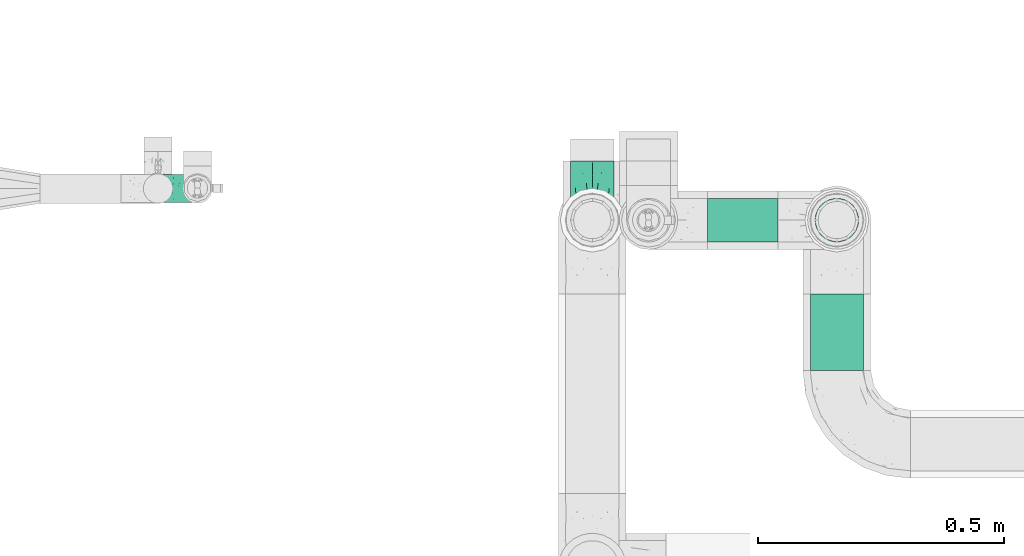
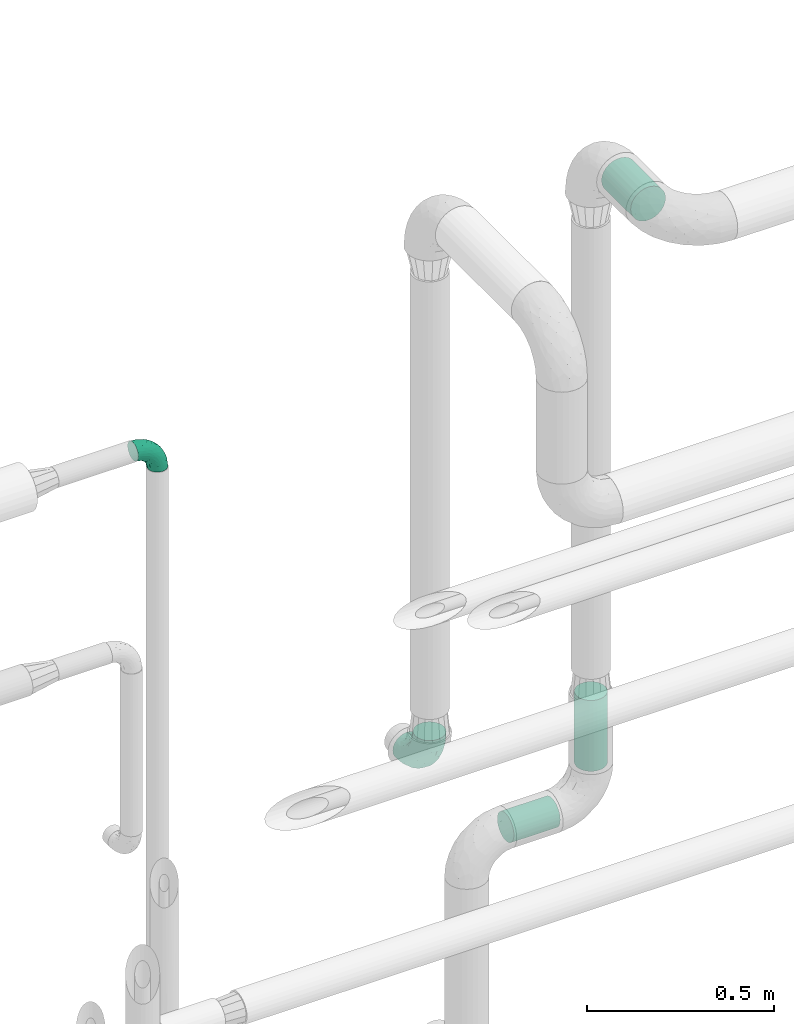
# One storey, part 720 of 827: 3 flow segments, 2 flow fittings.
"""IFC2X3 building model written with IfcOpenShell, lengths in millimetres."""

from ifc_helpers import new_model, entity, si_unit, converted_unit, derived_unit, direction, frame, origin, origin_2d_with_axis, place, context, subcontext, project, spatial, circle, extrude, faceted_brep, source, transform, mapped, material, type_object, type_shapes, element, save


model = new_model("IFC2X3")

# Units and contexts
model_context = context("Model", 3, precision=0.01, world=origin(), true_north=direction((6.12303176911189e-17, 1.0)))
body_context = subcontext(model_context, "Body", "Model", "MODEL_VIEW")
ifc_project = project(units=[si_unit("LENGTHUNIT", "METRE", prefix="MILLI"), si_unit("AREAUNIT", "SQUARE_METRE"), si_unit("VOLUMEUNIT", "CUBIC_METRE"), converted_unit("PLANEANGLEUNIT", "DEGREE", entity("IfcRatioMeasure", 0.0174532925199433), si_unit("PLANEANGLEUNIT", "RADIAN"), dimensions=[0, 0, 0, 0, 0, 0, 0]), si_unit("MASSUNIT", "GRAM", prefix="KILO"), derived_unit("MASSDENSITYUNIT", [(si_unit("MASSUNIT", "GRAM", prefix="KILO"), 1), (si_unit("LENGTHUNIT", "METRE"), -3)]), derived_unit("MOMENTOFINERTIAUNIT", [(si_unit("LENGTHUNIT", "METRE"), 4)]), si_unit("TIMEUNIT", "SECOND"), si_unit("FREQUENCYUNIT", "HERTZ"), si_unit("THERMODYNAMICTEMPERATUREUNIT", "DEGREE_CELSIUS"), derived_unit("THERMALTRANSMITTANCEUNIT", [(si_unit("MASSUNIT", "GRAM", prefix="KILO"), 1), (si_unit("THERMODYNAMICTEMPERATUREUNIT", "KELVIN"), -1), (si_unit("TIMEUNIT", "SECOND"), -3)]), derived_unit("VOLUMETRICFLOWRATEUNIT", [(si_unit("LENGTHUNIT", "METRE"), 3), (si_unit("TIMEUNIT", "SECOND"), -1)]), derived_unit("MASSFLOWRATEUNIT", [(si_unit("MASSUNIT", "GRAM", prefix="KILO"), 1), (si_unit("TIMEUNIT", "SECOND"), -1)]), derived_unit("ROTATIONALFREQUENCYUNIT", [(si_unit("TIMEUNIT", "SECOND"), -1)]), si_unit("ELECTRICCURRENTUNIT", "AMPERE"), si_unit("ELECTRICVOLTAGEUNIT", "VOLT"), si_unit("POWERUNIT", "WATT"), si_unit("FORCEUNIT", "NEWTON", prefix="KILO"), si_unit("ILLUMINANCEUNIT", "LUX"), si_unit("LUMINOUSFLUXUNIT", "LUMEN"), si_unit("LUMINOUSINTENSITYUNIT", "CANDELA"), derived_unit("USERDEFINED", [(si_unit("MASSUNIT", "GRAM", prefix="KILO"), -1), (si_unit("LENGTHUNIT", "METRE"), -2), (si_unit("TIMEUNIT", "SECOND"), 3), (si_unit("LUMINOUSFLUXUNIT", "LUMEN"), 1)]), derived_unit("LINEARVELOCITYUNIT", [(si_unit("LENGTHUNIT", "METRE"), 1), (si_unit("TIMEUNIT", "SECOND"), -1)]), si_unit("PRESSUREUNIT", "PASCAL"), derived_unit("USERDEFINED", [(si_unit("LENGTHUNIT", "METRE"), -2), (si_unit("MASSUNIT", "GRAM", prefix="KILO"), 1), (si_unit("TIMEUNIT", "SECOND"), -2)]), derived_unit("LINEARFORCEUNIT", [(si_unit("MASSUNIT", "GRAM", prefix="KILO"), 1), (si_unit("LENGTHUNIT", "METRE"), 1), (si_unit("TIMEUNIT", "SECOND"), -2), (si_unit("LENGTHUNIT", "METRE"), -1)]), derived_unit("PLANARFORCEUNIT", [(si_unit("MASSUNIT", "GRAM", prefix="KILO"), 1), (si_unit("LENGTHUNIT", "METRE"), 1), (si_unit("TIMEUNIT", "SECOND"), -2), (si_unit("LENGTHUNIT", "METRE"), -2)])], contexts=[model_context])

# Site, building, storey
site_placement = place(None, origin())
site = spatial("IfcSite", under=ifc_project, at=site_placement, CompositionType="ELEMENT")
building_placement = place(site_placement, origin())
building = spatial("IfcBuilding", under=site, at=building_placement, CompositionType="ELEMENT")
storey_placement = place(building_placement, frame((0.0, 0.0, 28200.0)))
storey = spatial("IfcBuildingStorey", under=building, at=storey_placement, Name="08", CompositionType="ELEMENT", Elevation=28200.0)

# Flow segments
pipe_segment_type = type_object("IfcPipeSegmentType", PredefinedType="NOTDEFINED")
flow_segment_1_placement = place(storey_placement, frame((56052.95, 18330.1, 3444.15)))
element("IfcFlowSegment", 1, at=flow_segment_1_placement, inside=storey, type_object=pipe_segment_type, context=body_context, shape_type="SweptSolid", body=[
    extrude(circle(Radius=54.0, at=origin_2d_with_axis()), frame((55.6, 0.0, 55.6), z_axis=(0.0, 1.0, 0.0), x_axis=(1.0, 0.0, 0.0)), (0.0, 0.0, 1.0), 155.890486759072),
])
flow_segment_2_placement = place(storey_placement, frame((55845.5, 18589.89, 1327.79)))
element("IfcFlowSegment", 2, at=flow_segment_2_placement, inside=storey, type_object=pipe_segment_type, context=body_context, shape_type="SweptSolid", body=[
    extrude(circle(Radius=44.5, at=origin_2d_with_axis()), frame((0.0, 46.1, 46.1), z_axis=(1.0, 0.0, 0.0), x_axis=(0.0, 1.0, 0.0)), (0.0, 0.0, 1.0), 143.048447506268),
])
flow_segment_3_placement = place(storey_placement, frame((56062.45, 18589.89, 1493.89)))
element("IfcFlowSegment", 3, at=flow_segment_3_placement, inside=storey, type_object=pipe_segment_type, context=body_context, shape_type="SweptSolid", body=[
    extrude(circle(Radius=44.5, at=origin_2d_with_axis()), frame((46.1, 46.1, 0.0)), (0.0, 0.0, 1.0), 231.111239088707),
])

# Flow fittings
ifc_material = material()
pipe_fitting_type_1 = type_object("IfcPipeFittingType", Name="ADSK_2", PredefinedType="NOTDEFINED", material=ifc_material)
shared_shape_1 = source(origin(), body_context, "Body", "Brep", [
    faceted_brep([(-120.0, 22.25, -38.54), (-120.0, 11.52, -42.98), (-120.0, 0.0, -44.5), (-120.0, -11.52, -42.98), (-120.0, -22.25, -38.54), (-120.0, -31.47, -31.47), (-120.0, -38.54, -22.25), (-120.0, -42.98, -11.52), (-120.0, -44.5, 0.0), (-120.0, -42.98, 11.52), (-120.0, -38.54, 22.25), (-120.0, -31.47, 31.47), (-120.0, -22.25, 38.54), (-120.0, -11.52, 42.98), (-120.0, 0.0, 44.5), (-120.0, 11.52, 42.98), (-120.0, 22.25, 38.54), (-120.0, 31.47, 31.47), (-120.0, 38.54, 22.25), (-120.0, 42.98, 11.52), (-120.0, 44.5, 0.0), (-120.0, 42.98, -11.52), (-120.0, 38.54, -22.25), (-120.0, 31.47, -31.47), (0.0, 120.0, -44.5), (-11.52, 120.0, -42.98), (-22.25, 120.0, -38.54), (-31.47, 120.0, -31.47), (-38.54, 120.0, -22.25), (-42.98, 120.0, -11.52), (-44.5, 120.0, 0.0), (-42.98, 120.0, 11.52), (-38.54, 120.0, 22.25), (-31.47, 120.0, 31.47), (-22.25, 120.0, 38.54), (-11.52, 120.0, 42.98), (0.0, 120.0, 44.5), (11.52, 120.0, 42.98), (22.25, 120.0, 38.54), (31.47, 120.0, 31.47), (38.54, 120.0, 22.25), (42.98, 120.0, 11.52), (44.5, 120.0, 0.0), (42.98, 120.0, -11.52), (38.54, 120.0, -22.25), (31.47, 120.0, -31.47), (22.25, 120.0, -38.54), (11.52, 120.0, -42.98), (-20.51, 85.66, 41.98), (-29.31, 93.55, 36.45), (-98.0, -41.6, 0.0), (-80.92, -37.22, 14.68), (-66.68, -9.63, 39.67), (-84.59, -24.55, 33.9), (-50.35, -12.87, 32.85), (-77.42, -38.89, 0.0), (-22.01, -9.62, 13.21), (-37.75, -22.46, 0.0), (-20.72, -9.39, 0.0), (-89.18, -33.47, 25.4), (12.87, 50.35, 32.85), (24.55, 84.59, 33.9), (9.63, 66.68, 39.67), (-49.55, -27.06, 11.21), (-28.67, -9.99, 21.67), (-52.01, -22.41, 23.47), (-95.53, -16.28, 40.49), (-86.01, -3.42, 43.77), (22.41, 52.01, 23.47), (9.05, 21.37, 13.44), (26.5, 49.37, 12.73), (33.47, 89.18, 25.4), (37.22, 80.92, 14.68), (16.28, 95.53, 40.49), (3.42, 86.01, 43.77), (-7.84, 52.6, 43.16), (-84.39, 31.88, 36.84), (-30.52, 34.28, 44.33), (-21.99, 28.55, 42.22), (-93.56, 38.23, 28.63), (-65.04, 31.74, 41.51), (-91.98, 19.0, 41.83), (-34.03, 70.24, 39.41), (-96.36, 44.0, 18.64), (-98.49, 46.74, 8.65), (-76.5, 56.97, 9.76), (-4.96, 4.47, 11.32), (-7.16, 6.18, 18.93), (-56.62, 75.93, 12.18), (-66.61, 66.61, 0.0), (-92.12, 7.25, 44.33), (-7.23, 92.66, 44.32), (30.68, 57.59, 0.0), (-44.45, 94.8, 18.75), (-36.39, 101.98, 28.14), (-46.83, 97.45, 9.69), (-38.03, 47.61, 43.21), (-24.7, 65.7, 43.29), (41.6, 98.0, 0.0), (-54.11, 72.8, 21.53), (-47.95, 9.75, 42.93), (-18.65, 18.65, 37.89), (-91.11, 50.25, 0.0), (-50.25, 91.11, 0.0), (-57.59, -30.68, 0.0), (-44.16, 67.2, 34.92), (-55.15, 62.16, 29.74), (-68.1, 47.21, 32.31), (-51.09, 51.09, 38.36), (-16.69, 62.62, 44.46), (-58.26, 18.84, 44.48), (-71.55, 55.71, 20.49), (-43.13, 80.04, 29.45), (-37.23, 0.88, 36.78), (-18.15, 10.22, 33.09), (5.51, 28.08, 26.74), (-3.68, 3.68, 0.0), (9.39, 20.72, 0.0), (-2.58, 27.98, 33.59), (-2.38, 41.22, 38.93), (-16.09, 4.55, 27.06), (38.89, 77.42, 0.0), (22.46, 37.75, 0.0), (-92.66, 7.23, -44.32), (-22.01, -9.62, -13.21), (-49.81, -26.66, -12.91), (-28.67, -9.99, -21.67), (-62.62, 16.69, -44.46), (-65.04, 31.74, -41.51), (-38.89, 47.26, -43.11), (-56.62, 75.93, -12.18), (-93.56, 38.23, -28.63), (-84.39, 31.88, -36.84), (16.28, 95.53, -40.49), (3.42, 86.01, -43.77), (-98.49, 46.74, -8.65), (-44.45, 94.8, -18.75), (-54.11, 72.8, -21.53), (-76.5, 56.97, -9.76), (24.55, 84.59, -33.9), (9.63, 66.68, -39.67), (-96.36, 44.0, -18.64), (-29.4, 93.16, -36.47), (-91.98, 19.0, -41.83), (-80.92, -37.22, -14.68), (-52.6, 7.84, -43.16), (-86.01, -3.42, -43.77), (-89.18, -33.47, -25.4), (-52.01, -22.41, -23.47), (-50.35, -12.87, -32.85), (-84.59, -24.55, -33.9), (-66.68, -9.63, -39.67), (-95.53, -16.28, -40.49), (-68.1, 47.21, -32.31), (-35.81, 11.1, -40.85), (-19.61, 28.53, -41.59), (-18.65, 18.65, -37.89), (-4.97, 4.47, -11.34), (9.05, 21.37, -13.44), (-34.28, 30.52, -44.33), (-9.75, 47.95, -42.93), (-2.58, 27.98, -33.59), (-18.15, 10.22, -33.09), (-46.83, 97.45, -9.69), (12.87, 50.35, -32.85), (26.8, 49.13, -11.4), (-7.34, 92.03, -44.33), (-21.02, 83.86, -42.03), (-44.6, 66.82, -34.8), (-55.46, 62.18, -29.47), (37.22, 80.92, -14.68), (33.47, 89.18, -25.4), (-34.39, 70.11, -39.28), (-25.04, 64.41, -43.37), (-18.84, 58.26, -44.48), (22.41, 52.01, -23.47), (-36.39, 101.98, -28.14), (-51.09, 51.09, -38.36), (-43.13, 80.04, -29.45), (-71.55, 55.71, -20.49), (-7.15, 6.2, -18.94), (5.51, 28.08, -26.74), (-37.23, 0.88, -36.78), (-2.38, 41.22, -38.93), (-16.09, 4.55, -27.06)], [[[0, 1, 2, 3, 4, 5, 6, 7, 8, 9, 10, 11, 12, 13, 14, 15, 16, 17, 18, 19, 20, 21, 22, 23]], [[24, 25, 26, 27, 28, 29, 30, 31, 32, 33, 34, 35, 36, 37, 38, 39, 40, 41, 42, 43, 44, 45, 46, 47]], [[48, 34, 49]], [[50, 51, 9]], [[52, 53, 54]], [[9, 51, 10]], [[55, 51, 50]], [[56, 57, 58]], [[51, 59, 10]], [[60, 61, 62]], [[63, 64, 65]], [[13, 12, 66]], [[67, 14, 13]], [[68, 69, 70]], [[71, 68, 72]], [[38, 73, 61]], [[74, 75, 62]], [[17, 16, 76]], [[77, 78, 75]], [[79, 18, 17]], [[80, 76, 81]], [[35, 34, 48]], [[49, 82, 48]], [[18, 83, 19]], [[16, 81, 76]], [[20, 19, 84]], [[85, 84, 83]], [[56, 86, 87]], [[85, 88, 89]], [[37, 36, 74]], [[90, 14, 67]], [[79, 17, 76]], [[63, 65, 51]], [[13, 66, 67]], [[61, 39, 38]], [[91, 74, 36]], [[70, 92, 72]], [[93, 94, 32]], [[95, 88, 93]], [[62, 73, 74]], [[82, 96, 97]], [[40, 72, 41]], [[72, 68, 70]], [[71, 72, 40]], [[34, 33, 49]], [[72, 98, 41]], [[99, 93, 88]], [[71, 39, 61]], [[78, 100, 101]], [[85, 89, 102]], [[53, 52, 66]], [[103, 95, 30]], [[12, 11, 53]], [[103, 89, 88]], [[104, 57, 63]], [[91, 48, 97]], [[93, 32, 31]], [[33, 32, 94]], [[16, 15, 81]], [[105, 106, 107]], [[76, 107, 79]], [[35, 91, 36]], [[80, 96, 108]], [[31, 95, 93]], [[65, 53, 59]], [[73, 38, 37]], [[75, 74, 109]], [[61, 60, 68]], [[11, 10, 59]], [[54, 53, 65]], [[100, 67, 52]], [[110, 81, 90]], [[15, 14, 90]], [[76, 80, 108]], [[107, 76, 108]], [[83, 79, 111]], [[94, 49, 33]], [[82, 105, 108]], [[84, 85, 102]], [[111, 88, 85]], [[99, 88, 111]], [[94, 93, 112]], [[48, 91, 35]], [[74, 91, 109]], [[69, 87, 86]], [[113, 54, 114]], [[64, 56, 87]], [[60, 115, 68]], [[116, 117, 86]], [[69, 68, 115]], [[79, 83, 18]], [[85, 83, 111]], [[81, 110, 80]], [[110, 77, 96]], [[110, 96, 80]], [[97, 96, 109]], [[107, 108, 105]], [[111, 79, 107]], [[77, 75, 109]], [[118, 119, 101]], [[96, 77, 109]], [[77, 110, 100]], [[67, 100, 110]], [[100, 52, 113]], [[60, 119, 118]], [[118, 120, 115]], [[64, 54, 65]], [[114, 120, 118]], [[118, 115, 60]], [[115, 120, 87]], [[74, 73, 37]], [[61, 73, 62]], [[53, 66, 12]], [[67, 66, 52]], [[110, 90, 67]], [[15, 90, 81]], [[105, 49, 112]], [[96, 82, 108]], [[119, 60, 62]], [[118, 101, 114]], [[62, 75, 119]], [[78, 119, 75]], [[49, 105, 82]], [[105, 112, 106]], [[99, 112, 93]], [[111, 107, 106]], [[113, 114, 101]], [[54, 120, 114]], [[100, 113, 101]], [[52, 54, 113]], [[20, 84, 102]], [[83, 84, 19]], [[111, 106, 99]], [[112, 99, 106]], [[100, 78, 77]], [[119, 78, 101]], [[39, 71, 40]], [[68, 71, 61]], [[65, 59, 51]], [[11, 59, 53]], [[30, 95, 31]], [[103, 88, 95]], [[9, 8, 50]], [[98, 72, 121]], [[98, 42, 41]], [[49, 94, 112]], [[56, 63, 57]], [[51, 55, 104]], [[92, 121, 72]], [[86, 58, 116]], [[54, 64, 120]], [[115, 87, 69]], [[120, 64, 87]], [[58, 86, 56]], [[86, 117, 69]], [[91, 97, 109]], [[122, 69, 117]], [[82, 97, 48]], [[63, 56, 64]], [[104, 63, 51]], [[69, 122, 70]], [[92, 70, 122]], [[123, 2, 1]], [[124, 125, 126]], [[127, 128, 129]], [[103, 130, 89]], [[23, 131, 132]], [[47, 133, 134]], [[102, 135, 20]], [[130, 136, 137]], [[102, 138, 135]], [[139, 140, 133]], [[22, 21, 141]], [[27, 26, 142]], [[46, 45, 139]], [[0, 143, 1]], [[6, 144, 7]], [[145, 146, 127]], [[144, 50, 7]], [[147, 148, 144]], [[144, 6, 147]], [[149, 150, 151]], [[4, 3, 152]], [[23, 22, 131]], [[132, 131, 153]], [[43, 42, 98]], [[125, 104, 144]], [[154, 155, 156]], [[146, 151, 152]], [[4, 150, 5]], [[123, 146, 2]], [[157, 158, 117]], [[130, 138, 89]], [[29, 28, 136]], [[159, 160, 155]], [[161, 162, 156]], [[89, 138, 102]], [[163, 30, 29]], [[164, 140, 139]], [[163, 136, 130]], [[23, 132, 0]], [[158, 165, 122]], [[25, 24, 166]], [[0, 132, 143]], [[4, 152, 150]], [[142, 26, 167]], [[3, 2, 146]], [[167, 26, 25]], [[133, 47, 46]], [[168, 153, 169]], [[146, 145, 151]], [[149, 126, 148]], [[44, 170, 171]], [[24, 47, 134]], [[170, 44, 43]], [[144, 148, 125]], [[170, 98, 121]], [[168, 142, 172]], [[129, 173, 174]], [[98, 170, 43]], [[147, 5, 150]], [[157, 58, 124]], [[92, 122, 165]], [[134, 166, 24]], [[175, 139, 171]], [[28, 27, 176]], [[29, 136, 163]], [[132, 128, 143]], [[45, 44, 171]], [[164, 139, 175]], [[160, 134, 140]], [[174, 173, 166]], [[141, 131, 22]], [[132, 153, 177]], [[128, 132, 177]], [[123, 143, 127]], [[172, 142, 167]], [[176, 142, 178]], [[130, 179, 138]], [[138, 179, 141]], [[176, 136, 28]], [[130, 137, 179]], [[174, 166, 134]], [[167, 25, 166]], [[143, 123, 1]], [[146, 123, 127]], [[150, 149, 148]], [[157, 124, 180]], [[181, 161, 164]], [[181, 158, 180]], [[124, 126, 180]], [[170, 165, 175]], [[141, 21, 135]], [[131, 141, 179]], [[131, 179, 153]], [[179, 137, 169]], [[129, 128, 177]], [[127, 143, 128]], [[129, 177, 172]], [[129, 174, 159]], [[159, 145, 127]], [[182, 154, 156]], [[129, 159, 127]], [[159, 174, 160]], [[134, 160, 174]], [[140, 164, 183]], [[162, 182, 156]], [[126, 149, 184]], [[181, 164, 175]], [[164, 161, 183]], [[158, 181, 175]], [[184, 162, 161]], [[146, 152, 3]], [[150, 152, 151]], [[139, 133, 46]], [[134, 133, 140]], [[184, 161, 181]], [[161, 156, 183]], [[155, 183, 156]], [[160, 140, 183]], [[184, 149, 162]], [[182, 162, 149]], [[149, 151, 182]], [[154, 151, 145]], [[151, 154, 182]], [[159, 154, 145]], [[159, 155, 154]], [[183, 155, 160]], [[141, 135, 138]], [[20, 135, 21]], [[136, 178, 137]], [[169, 178, 168]], [[172, 167, 173]], [[168, 172, 177]], [[153, 168, 177]], [[142, 168, 178]], [[179, 169, 153]], [[137, 178, 169]], [[5, 147, 6]], [[148, 147, 150]], [[175, 171, 170]], [[45, 171, 139]], [[130, 103, 163]], [[30, 163, 103]], [[50, 144, 55]], [[50, 8, 7]], [[142, 176, 27]], [[136, 176, 178]], [[126, 125, 148]], [[104, 55, 144]], [[170, 121, 92]], [[58, 57, 124]], [[180, 126, 184]], [[181, 180, 184]], [[180, 158, 157]], [[158, 122, 117]], [[58, 157, 116]], [[172, 173, 129]], [[116, 157, 117]], [[166, 173, 167]], [[124, 57, 125]], [[104, 125, 57]], [[175, 165, 158]], [[92, 165, 170]]]),
])
type_shapes(pipe_fitting_type_1, [shared_shape_1])
flow_fitting_1_placement = place(storey_placement, frame((55611.05, 18635.99, 1648.17), z_axis=(1.0, 0.0, 0.0), x_axis=(0.0, 0.0, -1.0)))
element("IfcFlowFitting", 4, at=flow_fitting_1_placement, inside=storey, type_object=pipe_fitting_type_1, material=ifc_material, Name="ADSK_2", ObjectType="ADSK_2", context=body_context, shape_type="MappedRepresentation", body=[
    mapped(shared_shape_1, transform((0.0, 0.0, 0.0), scale=1.0)),
])
pipe_fitting_type_2 = type_object("IfcPipeFittingType", Name="ADSK_2", PredefinedType="NOTDEFINED", material=ifc_material)
shared_shape_2 = source(origin(), body_context, "Body", "Brep", [
    faceted_brep([(-75.0, 0.0, -28.5), (-75.0, -7.38, -27.53), (-75.0, -14.25, -24.68), (-75.0, -20.15, -20.15), (-75.0, -24.68, -14.25), (-75.0, -27.53, -7.38), (-75.0, -28.5, 0.0), (-75.0, -27.53, 7.38), (-75.0, -24.68, 14.25), (-75.0, -20.15, 20.15), (-75.0, -14.25, 24.68), (-75.0, -7.38, 27.53), (-75.0, 0.0, 28.5), (-75.0, 7.38, 27.53), (-75.0, 14.25, 24.68), (-75.0, 20.15, 20.15), (-75.0, 24.68, 14.25), (-75.0, 27.53, 7.38), (-75.0, 28.5, 0.0), (-75.0, 27.53, -7.38), (-75.0, 24.68, -14.25), (-75.0, 20.15, -20.15), (-75.0, 14.25, -24.68), (-75.0, 7.38, -27.53), (-7.38, 75.0, -27.53), (-14.25, 75.0, -24.68), (-20.15, 75.0, -20.15), (-24.68, 75.0, -14.25), (-27.53, 75.0, -7.38), (-28.5, 75.0, 0.0), (-27.53, 75.0, 7.38), (-24.68, 75.0, 14.25), (-20.15, 75.0, 20.15), (-14.25, 75.0, 24.68), (-7.38, 75.0, 27.53), (0.0, 75.0, 28.5), (7.38, 75.0, 27.53), (14.25, 75.0, 24.68), (20.15, 75.0, 20.15), (24.68, 75.0, 14.25), (27.53, 75.0, 7.38), (28.5, 75.0, 0.0), (27.53, 75.0, -7.38), (24.68, 75.0, -14.25), (20.15, 75.0, -20.15), (14.25, 75.0, -24.68), (7.38, 75.0, -27.53), (0.0, 75.0, -28.5), (-58.34, -3.09, 28.08), (-53.36, 5.47, 28.42), (-60.98, -26.28, 0.0), (-50.38, -23.9, 9.36), (-2.72, 2.72, 0.0), (3.49, 8.33, 5.39), (-8.47, -3.6, 5.43), (-43.02, -23.43, 0.0), (9.86, 31.5, 19.95), (3.58, 31.64, 24.39), (0.78, 15.8, 19.09), (-55.53, -21.42, 16.31), (-41.02, 15.05, 27.84), (-38.36, 9.63, 28.5), (-24.63, 17.21, 28.45), (14.9, 48.57, 21.5), (-48.57, -14.9, 21.5), (-55.48, -9.89, 25.8), (-22.48, -12.99, 7.59), (-28.59, -16.08, 0.0), (-14.16, -8.73, 0.0), (-38.26, 22.79, 26.22), (-58.0, 11.98, 26.79), (-31.64, -3.58, 24.39), (-39.5, 2.0, 27.82), (-30.52, 53.58, 12.47), (-11.07, 64.24, 26.62), (-4.85, 56.28, 28.4), (-62.79, 17.89, 23.17), (-57.59, 24.67, 18.42), (-50.35, 32.08, 12.72), (-63.79, 27.28, 11.71), (-11.91, 27.95, 28.26), (-21.91, 10.04, 27.08), (-7.9, 23.21, 26.78), (8.73, 14.16, 0.0), (-61.42, 30.11, 4.72), (-44.0, 30.05, 19.91), (-2.0, 39.5, 27.82), (9.89, 55.48, 25.8), (-11.33, 11.33, 24.21), (-17.5, -1.61, 19.5), (13.94, 30.82, 14.87), (19.0, 37.09, 10.84), (21.42, 55.53, 16.31), (3.09, 58.34, 28.08), (-15.17, -4.71, 14.28), (-39.06, -21.55, 5.21), (-35.82, -18.71, 10.31), (23.9, 50.38, 9.36), (-30.11, 61.42, 4.72), (-38.06, 40.7, 14.41), (-33.21, 40.38, 19.56), (26.28, 60.98, 0.0), (-30.82, -13.94, 14.87), (-18.89, 57.68, 23.4), (-24.2, 59.35, 18.31), (-41.53, 41.53, 6.86), (-34.73, 51.75, 0.0), (-51.75, 34.73, 0.0), (-25.37, 39.36, 24.88), (-36.07, 30.61, 23.61), (-32.31, -9.26, 20.83), (-14.02, 50.19, 26.99), (-13.14, 36.54, 28.42), (16.08, 28.59, 0.0), (12.99, 22.48, 7.59), (20.38, 36.25, 5.56), (23.43, 43.02, 0.0), (-48.14, 22.05, 23.83), (-20.29, 38.18, 27.03), (-27.1, 27.1, 27.56), (6.41, 16.13, 12.8), (-4.24, 6.02, 15.65), (-3.26, 3.26, 10.59), (-64.24, 11.07, -26.62), (-48.57, -14.9, -21.5), (-56.28, 4.85, -28.4), (-59.35, 24.2, -18.31), (-57.68, 18.89, -23.4), (9.89, 55.48, -25.8), (3.58, 31.64, -24.39), (-2.0, 39.5, -27.82), (-61.42, 30.11, -4.72), (-30.11, 61.42, -4.72), (-41.53, 41.53, -6.86), (23.9, 50.38, -9.36), (21.42, 55.53, -16.31), (-50.19, 14.02, -26.99), (-39.36, 25.37, -24.88), (3.09, 58.34, -28.08), (-5.47, 53.36, -28.42), (-11.98, 58.0, -26.79), (-50.38, -23.9, -9.36), (13.94, 30.82, -14.87), (14.9, 48.57, -21.5), (-22.79, 38.26, -26.22), (-15.05, 41.02, -27.84), (-55.53, -21.42, -16.31), (-9.63, 38.36, -28.5), (-17.21, 24.63, -28.45), (-22.48, -12.99, -7.59), (-30.61, 36.07, -23.61), (-58.34, -3.09, -28.08), (-37.09, -19.0, -10.84), (-30.82, -13.94, -14.87), (21.55, 39.06, -5.21), (18.71, 35.82, -10.31), (-23.21, 7.9, -26.78), (-39.5, 2.0, -27.82), (-27.95, 11.91, -28.26), (-36.25, -20.38, -5.56), (-24.67, 57.59, -18.42), (3.6, 8.47, -5.43), (-8.33, -3.49, -5.39), (-17.89, 62.79, -23.17), (-32.46, -10.54, -19.76), (-31.64, -3.58, -24.39), (-17.5, -1.61, -19.5), (-10.04, 21.91, -27.08), (-32.08, 50.35, -12.72), (-27.28, 63.79, -11.71), (-30.05, 44.0, -19.91), (-40.38, 33.21, -19.56), (-55.48, -9.89, -25.8), (-53.58, 30.52, -12.47), (12.99, 22.48, -7.59), (9.13, 31.36, -20.52), (-15.17, -4.71, -14.28), (-4.24, 6.02, -15.65), (-3.26, 3.26, -10.59), (-40.7, 38.06, -14.41), (-36.54, 13.14, -28.42), (-22.05, 48.14, -23.83), (-38.18, 20.29, -27.03), (-11.33, 11.33, -24.21), (0.78, 15.8, -19.09), (-27.1, 27.1, -27.56), (6.41, 16.13, -12.8)], [[[0, 1, 2, 3, 4, 5, 6, 7, 8, 9, 10, 11, 12, 13, 14, 15, 16, 17, 18, 19, 20, 21, 22, 23]], [[24, 25, 26, 27, 28, 29, 30, 31, 32, 33, 34, 35, 36, 37, 38, 39, 40, 41, 42, 43, 44, 45, 46, 47]], [[12, 48, 49]], [[50, 51, 7]], [[52, 53, 54]], [[7, 51, 8]], [[55, 51, 50]], [[56, 57, 58]], [[9, 8, 59]], [[60, 61, 62]], [[63, 38, 37]], [[64, 10, 9]], [[64, 65, 10]], [[66, 67, 68]], [[69, 70, 60]], [[65, 71, 72]], [[31, 30, 73]], [[13, 70, 14]], [[34, 74, 75]], [[14, 76, 15]], [[11, 48, 12]], [[77, 78, 79]], [[80, 81, 82]], [[15, 77, 16]], [[52, 83, 53]], [[18, 17, 84]], [[79, 17, 16]], [[12, 49, 13]], [[77, 85, 78]], [[82, 86, 80]], [[37, 87, 63]], [[88, 71, 89]], [[90, 91, 92]], [[39, 38, 92]], [[87, 37, 36]], [[35, 93, 36]], [[94, 66, 54]], [[35, 34, 75]], [[95, 96, 51]], [[39, 97, 40]], [[98, 30, 29]], [[92, 97, 39]], [[99, 100, 73]], [[97, 101, 40]], [[59, 102, 64]], [[63, 87, 57]], [[100, 103, 104]], [[105, 106, 107]], [[51, 59, 8]], [[106, 98, 29]], [[69, 108, 109]], [[84, 105, 107]], [[89, 71, 110]], [[104, 103, 32]], [[33, 32, 103]], [[108, 111, 103]], [[111, 112, 75]], [[74, 103, 111]], [[74, 34, 33]], [[18, 84, 107]], [[10, 65, 11]], [[113, 114, 83]], [[115, 116, 97]], [[70, 13, 49]], [[76, 77, 15]], [[117, 109, 85]], [[32, 31, 104]], [[111, 108, 118]], [[111, 118, 112]], [[93, 75, 86]], [[71, 65, 64]], [[48, 65, 72]], [[110, 102, 89]], [[71, 88, 81]], [[93, 87, 36]], [[86, 82, 57]], [[86, 57, 87]], [[57, 88, 58]], [[59, 51, 96]], [[64, 9, 59]], [[38, 63, 92]], [[90, 92, 63]], [[60, 70, 49]], [[76, 70, 117]], [[103, 100, 108]], [[69, 109, 117]], [[62, 112, 119]], [[86, 75, 112]], [[62, 119, 60]], [[62, 72, 81]], [[89, 58, 88]], [[52, 54, 68]], [[31, 73, 104]], [[100, 104, 73]], [[102, 94, 89]], [[120, 58, 121]], [[89, 94, 121]], [[58, 90, 56]], [[75, 93, 35]], [[87, 93, 86]], [[65, 48, 11]], [[49, 48, 72]], [[60, 49, 61]], [[69, 60, 119]], [[99, 105, 78]], [[98, 105, 73]], [[7, 6, 50]], [[101, 97, 116]], [[101, 41, 40]], [[96, 95, 66]], [[96, 66, 102]], [[91, 114, 115]], [[115, 114, 113]], [[114, 90, 120]], [[79, 84, 17]], [[105, 84, 78]], [[105, 98, 106]], [[73, 30, 98]], [[70, 76, 14]], [[77, 76, 117]], [[49, 72, 61]], [[72, 62, 61]], [[108, 69, 119]], [[70, 69, 117]], [[108, 100, 109]], [[85, 109, 100]], [[85, 100, 99]], [[117, 85, 77]], [[71, 81, 72]], [[82, 81, 88]], [[57, 82, 88]], [[86, 112, 80]], [[112, 62, 80]], [[81, 80, 62]], [[77, 79, 16]], [[84, 79, 78]], [[103, 74, 33]], [[75, 74, 111]], [[105, 99, 73]], [[85, 99, 78]], [[108, 119, 118]], [[112, 118, 119]], [[122, 54, 53]], [[83, 114, 53]], [[120, 53, 114]], [[94, 54, 122]], [[66, 68, 54]], [[71, 64, 110]], [[102, 110, 64]], [[66, 94, 102]], [[121, 94, 122]], [[120, 121, 122]], [[89, 121, 58]], [[120, 122, 53]], [[58, 120, 90]], [[90, 63, 56]], [[57, 56, 63]], [[59, 96, 102]], [[51, 55, 95]], [[55, 67, 95]], [[66, 95, 67]], [[116, 115, 113]], [[91, 115, 97]], [[92, 91, 97]], [[114, 91, 90]], [[123, 23, 22]], [[124, 3, 2]], [[0, 23, 125]], [[23, 123, 125]], [[126, 127, 21]], [[128, 129, 130]], [[107, 131, 18]], [[29, 132, 106]], [[133, 107, 106]], [[134, 135, 43]], [[136, 127, 137]], [[47, 138, 139]], [[140, 24, 139]], [[123, 127, 136]], [[4, 141, 5]], [[135, 142, 143]], [[141, 50, 5]], [[144, 140, 145]], [[141, 4, 146]], [[145, 147, 148]], [[149, 68, 67]], [[22, 21, 127]], [[144, 137, 150]], [[42, 41, 101]], [[151, 1, 0]], [[152, 146, 153]], [[154, 155, 134]], [[156, 157, 158]], [[132, 133, 106]], [[159, 55, 141]], [[29, 28, 132]], [[47, 139, 24]], [[26, 160, 27]], [[52, 161, 83]], [[68, 162, 52]], [[26, 25, 163]], [[140, 25, 24]], [[164, 165, 166]], [[47, 46, 138]], [[158, 167, 156]], [[160, 168, 169]], [[168, 160, 170]], [[171, 127, 126]], [[45, 143, 128]], [[172, 124, 2]], [[131, 19, 18]], [[20, 19, 173]], [[113, 83, 174]], [[44, 43, 135]], [[143, 45, 44]], [[134, 42, 101]], [[175, 129, 143]], [[134, 101, 116]], [[172, 2, 1]], [[124, 172, 165]], [[42, 134, 43]], [[45, 128, 46]], [[176, 177, 178]], [[179, 171, 173]], [[169, 28, 27]], [[4, 3, 146]], [[136, 180, 125]], [[163, 160, 26]], [[181, 150, 170]], [[21, 20, 126]], [[136, 137, 182]], [[136, 182, 180]], [[151, 125, 157]], [[151, 172, 1]], [[157, 156, 165]], [[157, 165, 172]], [[165, 183, 166]], [[129, 128, 143]], [[138, 128, 130]], [[175, 142, 184]], [[129, 183, 167]], [[3, 124, 146]], [[146, 124, 164]], [[135, 134, 155]], [[143, 44, 135]], [[145, 140, 139]], [[163, 140, 181]], [[127, 171, 137]], [[144, 150, 181]], [[148, 180, 185]], [[157, 125, 180]], [[148, 185, 145]], [[148, 130, 167]], [[52, 162, 161]], [[153, 164, 166]], [[20, 173, 126]], [[171, 126, 173]], [[184, 166, 183]], [[176, 153, 166]], [[129, 184, 183]], [[177, 186, 178]], [[125, 151, 0]], [[172, 151, 157]], [[128, 138, 46]], [[139, 138, 130]], [[145, 139, 147]], [[144, 145, 185]], [[179, 133, 168]], [[131, 133, 173]], [[50, 141, 55]], [[50, 6, 5]], [[152, 149, 159]], [[159, 149, 67]], [[149, 153, 176]], [[186, 174, 161]], [[155, 154, 174]], [[155, 174, 142]], [[133, 131, 107]], [[173, 19, 131]], [[169, 132, 28]], [[133, 132, 168]], [[140, 163, 25]], [[160, 163, 181]], [[139, 130, 147]], [[130, 148, 147]], [[137, 144, 185]], [[140, 144, 181]], [[137, 171, 150]], [[170, 150, 171]], [[170, 171, 179]], [[181, 170, 160]], [[129, 167, 130]], [[156, 167, 183]], [[165, 156, 183]], [[157, 180, 158]], [[180, 148, 158]], [[167, 158, 148]], [[160, 169, 27]], [[132, 169, 168]], [[127, 123, 22]], [[125, 123, 136]], [[133, 179, 173]], [[170, 179, 168]], [[137, 185, 182]], [[180, 182, 185]], [[149, 176, 162]], [[149, 162, 68]], [[162, 178, 161]], [[186, 161, 178]], [[174, 83, 161]], [[146, 164, 153]], [[165, 164, 124]], [[177, 166, 184]], [[176, 178, 162]], [[166, 177, 176]], [[186, 184, 142]], [[184, 186, 177]], [[174, 186, 142]], [[142, 175, 143]], [[184, 129, 175]], [[55, 159, 67]], [[152, 159, 141]], [[146, 152, 141]], [[149, 152, 153]], [[135, 155, 142]], [[134, 116, 154]], [[116, 113, 154]], [[174, 154, 113]]]),
])
type_shapes(pipe_fitting_type_2, [shared_shape_2])
flow_fitting_2_placement = place(storey_placement, frame((54808.07, 18700.2, 2950.0), z_axis=(0.0, 1.0, 0.0), x_axis=(1.0, 0.0, 0.0)))
element("IfcFlowFitting", 5, at=flow_fitting_2_placement, inside=storey, type_object=pipe_fitting_type_2, material=ifc_material, Name="ADSK_2", ObjectType="ADSK_2", context=body_context, shape_type="MappedRepresentation", body=[
    mapped(shared_shape_2, transform((0.0, 0.0, 0.0), scale=1.0)),
])

save(model, "model.ifc")
